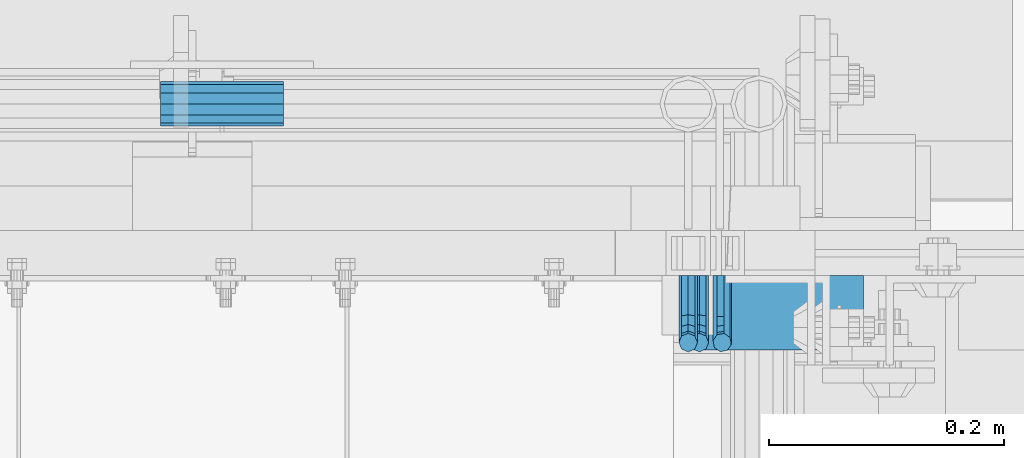
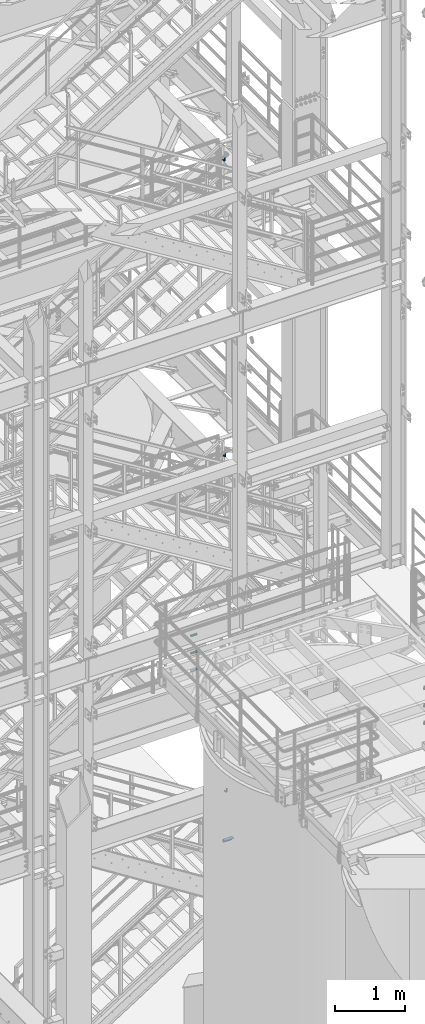
# One storey, part 1204 of 1876: 7 beams, 5 elements without a shape of their own.
"""IFC2X3 building model written with IfcOpenShell, lengths in millimetres."""

from ifc_helpers import new_model, si_unit, frame, origin_with_axes, place, context, subcontext, project, spatial, faceted_brep, material, type_object, element, aggregate, save


model = new_model("IFC2X3")

# Units and contexts
model_context = context("Model", 3, precision=1e-05, world=origin_with_axes())
body_context = subcontext(model_context, "Body", "Model", "MODEL_VIEW")
ifc_project = project(units=[si_unit("LENGTHUNIT", "METRE", prefix="MILLI"), si_unit("AREAUNIT", "SQUARE_METRE"), si_unit("VOLUMEUNIT", "CUBIC_METRE"), si_unit("MASSUNIT", "GRAM", prefix="KILO"), si_unit("TIMEUNIT", "SECOND"), si_unit("PLANEANGLEUNIT", "RADIAN"), si_unit("SOLIDANGLEUNIT", "STERADIAN"), si_unit("THERMODYNAMICTEMPERATUREUNIT", "DEGREE_CELSIUS"), si_unit("LUMINOUSINTENSITYUNIT", "LUMEN")], contexts=[model_context])

# Site, building, storey
site_placement = place(None, origin_with_axes())
site = spatial("IfcSite", under=ifc_project, at=site_placement, CompositionType="ELEMENT")
building_placement = place(site_placement, origin_with_axes())
building = spatial("IfcBuilding", under=site, at=building_placement, Name="Undefined", CompositionType="ELEMENT")
storey_placement = place(building_placement, origin_with_axes())
storey = spatial("IfcBuildingStorey", under=building, at=storey_placement, Name="Undefined", CompositionType="ELEMENT", Elevation=0.0)

# Assembly, beam
assembly_1_placement = place(storey_placement, origin_with_axes())
assembly_1 = element("IfcElementAssembly", 1, at=assembly_1_placement, inside=storey, Name="STRINGER", AssemblyPlace="NOTDEFINED", PredefinedType="RIGID_FRAME")
ifc_material = material(Name="STEEL/A36")
beam_type_1 = type_object("IfcBeamType", Name="L2-1/2X2-1/2X1/4", PredefinedType="NOTDEFINED")
beam_1_placement = place(assembly_1_placement, frame((6134.10000011796, -4832.34999887347, 2266.27941801296), z_axis=(0.0, -1.0, 0.0), x_axis=(1.0, 0.0, 0.0)))
beam_1 = element("IfcBeam", 2, at=beam_1_placement, type_object=beam_type_1, material=ifc_material, Name="ANGLE", ObjectType="L2-1/2X2-1/2X1/4", context=body_context, shape_type="Brep", body=[
    faceted_brep([(0.0, 31.75, -31.75), (0.0, 31.75, 31.75), (152.400073242188, 31.75, 31.75), (152.400073242188, 31.75, -31.75), (0.0, 25.3999999999996, 31.75), (152.400073242188, 25.3999999999996, 31.75), (0.0, 25.3999999999996, -25.3999999999996), (152.400073242188, 25.3999999999996, -25.3999999999996), (0.0, -31.75, -25.3999999999996), (152.400073242188, -31.75, -25.3999999999996), (0.0, -31.75, -31.75), (152.400073242188, -31.75, -31.75)], [[[0, 1, 2, 3]], [[1, 4, 5, 2]], [[4, 6, 7, 5]], [[6, 8, 9, 7]], [[8, 10, 11, 9]], [[10, 0, 3, 11]], [[5, 7, 9, 11, 3, 2]], [[10, 8, 6, 4, 1, 0]]]),
])
aggregate(assembly_1, [beam_1])

assembly_2_placement = place(storey_placement, origin_with_axes())
assembly_2 = element("IfcElementAssembly", 3, at=assembly_2_placement, inside=storey, Name="RAIL", AssemblyPlace="NOTDEFINED", PredefinedType="RIGID_FRAME")
beam_type_2 = type_object("IfcBeamType", PredefinedType="NOTDEFINED")
beam_2_placement = place(assembly_2_placement, frame((6146.79999403857, -4800.59999885446, 8978.89999872102), z_axis=(1.0, 0.0, 0.0), x_axis=(0.0, -1.0, 0.0)))
beam_2 = element("IfcBeam", 4, at=beam_2_placement, type_object=beam_type_2, material=ifc_material, Name="BRACKET", context=body_context, shape_type="Brep", body=[
    faceted_brep([(0.0, -7.9375, 0.0), (0.0, -5.61266007566822, -5.61266007566883), (23.8125, -5.61266007566883, -5.61266007566792), (23.8125, -7.9375, 0.0), (0.0, 0.0, -7.9375), (23.8125, 0.0, -7.9375), (0.0, 5.61266007566822, -5.61266007566883), (23.8125, 5.61266007566883, -5.61266007566792), (0.0, 7.9375, 0.0), (23.8125, 7.9375, 0.0), (0.0, 5.61266007566822, 5.61266007566883), (23.8125, 5.61266007566883, 5.61266007566792), (0.0, 0.0, 7.9375), (23.8125, 0.0, 7.9375), (0.0, -5.61266007566822, 5.61266007566883), (23.8125, -5.61266007566883, 5.61266007566792), (39.6077592547972, 4.79562758825296, 0.0), (38.7180815328547, 2.64775556579752, -5.61266007566792), (36.5702095103989, -2.53766620105534, -7.9375), (34.4223374879439, -7.72308796790867, -5.61266007566792), (33.5326597660014, -9.87095999036364, 0.0), (34.4223374879439, -7.72308796790867, 5.61266007566792), (36.5702095103989, -2.53766620105534, 7.9375), (38.7180815328547, 2.64775556579752, 5.61266007566792), (51.354423396765, -5.79557812911253, 5.61266007566792), (52.9983334724338, -4.15166805344461, 0.0), (47.385673396765, -9.76432812911298, 7.9375), (43.4169233967659, -13.733078129113, 5.61266007566792), (41.7730133210971, -15.3769882047809, 0.0), (43.4169233967659, -13.733078129113, -5.61266007566792), (47.385673396765, -9.76432812911298, -7.9375), (51.354423396765, -5.79557812911253, -5.61266007566792), (59.7977570916764, -18.4319199930233, 5.61266007566792), (61.9456291141314, -17.5422422710808, 0.0), (54.6123353248231, -20.5797920154787, 7.9375), (49.4269135579698, -22.7276640379341, 5.61266007566792), (47.2790415355148, -23.6173417598766, 0.0), (49.4269135579698, -22.7276640379341, -5.61266007566792), (54.6123353248231, -20.5797920154787, -7.9375), (59.7977570916764, -18.4319199930233, -5.61266007566792), (62.7626616015468, -33.3375015258789, 5.61266007566792), (65.0875015258789, -33.3375015258789, 0.0), (57.1500015258789, -33.3375015258789, 7.9375), (51.5373414502101, -33.3375015258789, 5.61266007566792), (49.2125015258789, -33.3375015258789, 0.0), (51.5373414502101, -33.3375015258789, -5.61266007566792), (57.1500015258789, -33.3375015258789, -7.9375), (62.7626616015468, -33.3375015258789, -5.61266007566792), (51.537341450211, -69.8499984741211, -5.61266007566792), (49.2125015258789, -69.8499984741211, 0.0), (57.1500015258789, -69.8499984741211, -7.9375), (62.7626616015468, -69.8499984741211, -5.61266007566792), (65.0875015258789, -69.8499984741211, 0.0), (62.7626616015468, -69.8499984741211, 5.61266007566792), (57.1500015258789, -69.8499984741211, 7.9375), (51.537341450211, -69.8499984741211, 5.61266007566792)], [[[0, 1, 2, 3]], [[1, 4, 5, 2]], [[4, 6, 7, 5]], [[6, 8, 9, 7]], [[8, 10, 11, 9]], [[10, 12, 13, 11]], [[12, 14, 15, 13]], [[14, 0, 3, 15]], [[14, 12, 10, 8, 6, 4, 1, 0]], [[7, 9, 16, 17]], [[5, 7, 17, 18]], [[2, 5, 18, 19]], [[3, 2, 19, 20]], [[15, 3, 20, 21]], [[13, 15, 21, 22]], [[11, 13, 22, 23]], [[9, 11, 23, 16]], [[23, 24, 25, 16]], [[22, 26, 24, 23]], [[21, 27, 26, 22]], [[20, 28, 27, 21]], [[19, 29, 28, 20]], [[18, 30, 29, 19]], [[17, 31, 30, 18]], [[16, 25, 31, 17]], [[24, 32, 33, 25]], [[26, 34, 32, 24]], [[27, 35, 34, 26]], [[28, 36, 35, 27]], [[29, 37, 36, 28]], [[30, 38, 37, 29]], [[31, 39, 38, 30]], [[25, 33, 39, 31]], [[32, 40, 41, 33]], [[34, 42, 40, 32]], [[35, 43, 42, 34]], [[36, 44, 43, 35]], [[37, 45, 44, 36]], [[38, 46, 45, 37]], [[39, 47, 46, 38]], [[33, 41, 47, 39]], [[44, 45, 48, 49]], [[45, 46, 50, 48]], [[46, 47, 51, 50]], [[47, 41, 52, 51]], [[41, 40, 53, 52]], [[40, 42, 54, 53]], [[42, 43, 55, 54]], [[43, 44, 49, 55]], [[50, 51, 52, 53, 54, 55, 49, 48]]]),
])
aggregate(assembly_2, [beam_2])

assembly_3_placement = place(storey_placement, origin_with_axes())
assembly_3 = element("IfcElementAssembly", 5, at=assembly_3_placement, inside=storey, Name="RAIL", AssemblyPlace="NOTDEFINED", PredefinedType="RIGID_FRAME")
beam_3_placement = place(assembly_3_placement, frame((6137.27499995292, -4800.59999885446, 14135.1), z_axis=(1.0, 0.0, 0.0), x_axis=(0.0, -1.0, 0.0)))
beam_3 = element("IfcBeam", 6, at=beam_3_placement, type_object=beam_type_2, material=ifc_material, Name="BRACKET", context=body_context, shape_type="Brep", body=[
    faceted_brep([(0.0, -7.9375, 0.0), (0.0, -5.61266007566822, -5.61266007566883), (23.8125, -5.61266007566883, -5.61266007566792), (23.8125, -7.9375, 0.0), (0.0, 0.0, -7.9375), (23.8125, 0.0, -7.9375), (0.0, 5.61266007566822, -5.61266007566883), (23.8125, 5.61266007566883, -5.61266007566792), (0.0, 7.9375, 0.0), (23.8125, 7.9375, 0.0), (0.0, 5.61266007566822, 5.61266007566883), (23.8125, 5.61266007566883, 5.61266007566792), (0.0, 0.0, 7.9375), (23.8125, 0.0, 7.9375), (0.0, -5.61266007566822, 5.61266007566883), (23.8125, -5.61266007566883, 5.61266007566792), (39.6077592547972, 4.79562758825296, 0.0), (38.7180815328547, 2.64775556579752, -5.61266007566792), (36.5702095103989, -2.53766620105534, -7.9375), (34.4223374879439, -7.72308796790867, -5.61266007566792), (33.5326597660014, -9.87095999036364, 0.0), (34.4223374879439, -7.72308796790867, 5.61266007566792), (36.5702095103989, -2.53766620105534, 7.9375), (38.7180815328547, 2.64775556579752, 5.61266007566792), (51.354423396765, -5.79557812911253, 5.61266007566792), (52.9983334724338, -4.15166805344461, 0.0), (47.385673396765, -9.76432812911298, 7.9375), (43.4169233967659, -13.733078129113, 5.61266007566792), (41.7730133210971, -15.3769882047809, 0.0), (43.4169233967659, -13.733078129113, -5.61266007566792), (47.385673396765, -9.76432812911298, -7.9375), (51.354423396765, -5.79557812911253, -5.61266007566792), (59.7977570916764, -18.4319199930233, 5.61266007566792), (61.9456291141314, -17.5422422710808, 0.0), (54.6123353248231, -20.5797920154787, 7.9375), (49.4269135579698, -22.7276640379341, 5.61266007566792), (47.2790415355148, -23.6173417598766, 0.0), (49.4269135579698, -22.7276640379341, -5.61266007566792), (54.6123353248231, -20.5797920154787, -7.9375), (59.7977570916764, -18.4319199930233, -5.61266007566792), (62.7626616015468, -33.3375015258789, 5.61266007566792), (65.0875015258789, -33.3375015258789, 0.0), (57.1500015258789, -33.3375015258789, 7.9375), (51.5373414502101, -33.3375015258789, 5.61266007566792), (49.2125015258789, -33.3375015258789, 0.0), (51.5373414502101, -33.3375015258789, -5.61266007566792), (57.1500015258789, -33.3375015258789, -7.9375), (62.7626616015468, -33.3375015258789, -5.61266007566792), (51.537341450211, -69.8499984741211, -5.61266007566792), (49.2125015258789, -69.8499984741211, 0.0), (57.1500015258789, -69.8499984741211, -7.9375), (62.7626616015468, -69.8499984741211, -5.61266007566792), (65.0875015258789, -69.8499984741211, 0.0), (62.7626616015468, -69.8499984741211, 5.61266007566792), (57.1500015258789, -69.8499984741211, 7.9375), (51.537341450211, -69.8499984741211, 5.61266007566792)], [[[0, 1, 2, 3]], [[1, 4, 5, 2]], [[4, 6, 7, 5]], [[6, 8, 9, 7]], [[8, 10, 11, 9]], [[10, 12, 13, 11]], [[12, 14, 15, 13]], [[14, 0, 3, 15]], [[14, 12, 10, 8, 6, 4, 1, 0]], [[7, 9, 16, 17]], [[5, 7, 17, 18]], [[2, 5, 18, 19]], [[3, 2, 19, 20]], [[15, 3, 20, 21]], [[13, 15, 21, 22]], [[11, 13, 22, 23]], [[9, 11, 23, 16]], [[23, 24, 25, 16]], [[22, 26, 24, 23]], [[21, 27, 26, 22]], [[20, 28, 27, 21]], [[19, 29, 28, 20]], [[18, 30, 29, 19]], [[17, 31, 30, 18]], [[16, 25, 31, 17]], [[24, 32, 33, 25]], [[26, 34, 32, 24]], [[27, 35, 34, 26]], [[28, 36, 35, 27]], [[29, 37, 36, 28]], [[30, 38, 37, 29]], [[31, 39, 38, 30]], [[25, 33, 39, 31]], [[32, 40, 41, 33]], [[34, 42, 40, 32]], [[35, 43, 42, 34]], [[36, 44, 43, 35]], [[37, 45, 44, 36]], [[38, 46, 45, 37]], [[39, 47, 46, 38]], [[33, 41, 47, 39]], [[44, 45, 48, 49]], [[45, 46, 50, 48]], [[46, 47, 51, 50]], [[47, 41, 52, 51]], [[41, 40, 53, 52]], [[40, 42, 54, 53]], [[42, 43, 55, 54]], [[43, 44, 49, 55]], [[50, 51, 52, 53, 54, 55, 49, 48]]]),
])
aggregate(assembly_3, [beam_3])

assembly_4_placement = place(storey_placement, origin_with_axes())
assembly_4 = element("IfcElementAssembly", 7, at=assembly_4_placement, inside=storey, Name="RAIL", AssemblyPlace="NOTDEFINED", PredefinedType="RIGID_FRAME")
beam_4_placement = place(assembly_4_placement, frame((6166.24687501242, -4800.59999885446, 3129.78376806244), z_axis=(0.844410015326383, 0.0, 0.535697420207059), x_axis=(0.0, -1.0, 0.0)))
beam_4 = element("IfcBeam", 8, at=beam_4_placement, type_object=beam_type_2, material=ifc_material, Name="BRACKET", context=body_context, shape_type="Brep", body=[
    faceted_brep([(0.0, -5.61266007566822, 5.61266007566883), (0.0, 0.0, 7.9375), (0.0, 5.61266007566822, 5.61266007566883), (0.0, 7.9375, 0.0), (0.0, 5.61266007566822, -5.61266007566883), (0.0, 0.0, -7.9375), (0.0, -5.61266007566822, -5.61266007566883), (0.0, -7.9375, 0.0), (25.7500019073486, 7.93750000000102, 9.09494701772928e-13), (25.7500019073486, 5.61266007566837, -5.61266007566837), (25.7500019073486, -6.82121026329696e-13, -7.93750000000091), (25.7500019073486, -5.6126600756694, -5.61266007566974), (25.7500019073486, -7.93750000000102, -1.81898940354586e-12), (25.7500019073486, -5.61266007566837, 5.61266007566746), (25.7500019073486, 6.82121026329696e-13, 7.93750000000045), (25.7500019073486, 5.6126600756694, 5.61266007566928), (38.4293366836664, 3.48299342205155, 6.96372994876174), (40.3311989638523, 5.48838972025123, 1.55372631168893), (40.7305556863994, 3.09647240503659, -4.01637957277262), (39.3934690994565, -2.29160580041184, -6.48369522136136), (37.103186391596, -7.51958175847221, -4.40290058978781), (35.20132411141, -9.5249780566719, 1.00710304728545), (34.8019673888657, -7.13306074145851, 6.57720893174746), (36.1390539758049, -1.74498253600871, 9.04452458033529), (44.9464670438292, -6.71427237123442, 12.1970638641865), (49.1783576787429, -2.58178409626339, 10.8112514273389), (42.4758531820917, -11.4627955199268, 9.32401168030583), (43.2137681863505, -14.0457330830792, 3.87508987960746), (46.7279514549882, -12.95003526696, -0.957797047369695), (50.9598420899019, -8.81754699198905, -2.34360948421772), (53.4304559516395, -4.06902384329646, 0.529442699663377), (52.6925409473806, -1.48608628014392, 5.97836450036175), (56.3606238862012, -11.6583650794599, 16.5694742441578), (60.952125596792, -11.9241272539106, 12.6003035112408), (50.8313923112155, -14.1513401749901, 16.9151723234295), (47.6033797389591, -17.942701540198, 13.4348925027043), (48.5675121547501, -20.8115211072019, 8.16733550011031), (53.159013865341, -21.0772832816523, 4.19816476719325), (58.6882454403267, -18.5843081861219, 3.85246668792206), (61.916258012584, -14.7929468209162, 7.33274650864814), (63.8525060225302, -24.2366360838653, 20.4114131579445), (64.8960754294303, -27.4426764670732, 15.3577905213597), (58.8827003833576, -22.3649223522546, 23.3617611737764), (52.8979032529824, -22.9239597913389, 22.4805607149005), (49.4039276223266, -25.5862718511769, 18.2840070589591), (50.4474970292276, -28.7923122343848, 13.2303844223738), (55.4173026683993, -30.6640259659952, 10.2800364065429), (61.4020997987745, -30.104988526911, 11.1612368654173), (64.8960754294312, -59.9102425789932, 35.955356977126), (61.4020997987755, -62.5725529476152, 31.7588022482705), (55.4173026684002, -63.1315900315748, 30.8776015641024), (50.4474970292276, -61.2598774889583, 33.8279503342364), (49.4039276223266, -58.0538391423651, 38.8815742628567), (52.8979032529824, -55.3915287737431, 43.0781289917122), (58.8827003833576, -54.8324916897835, 43.9593296758803), (63.8525060225302, -56.7042042324005, 41.0089809057463)], [[[0, 1, 2, 3, 4, 5, 6, 7]], [[4, 3, 8, 9]], [[5, 4, 9, 10]], [[6, 5, 10, 11]], [[7, 6, 11, 12]], [[0, 7, 12, 13]], [[1, 0, 13, 14]], [[2, 1, 14, 15]], [[3, 2, 15, 8]], [[8, 15, 16, 17]], [[9, 8, 17, 18]], [[10, 9, 18, 19]], [[11, 10, 19, 20]], [[12, 11, 20, 21]], [[13, 12, 21, 22]], [[14, 13, 22, 23]], [[15, 14, 23, 16]], [[23, 24, 25, 16]], [[22, 26, 24, 23]], [[21, 27, 26, 22]], [[20, 28, 27, 21]], [[19, 29, 28, 20]], [[18, 30, 29, 19]], [[17, 31, 30, 18]], [[16, 25, 31, 17]], [[25, 32, 33, 31]], [[24, 34, 32, 25]], [[26, 35, 34, 24]], [[27, 36, 35, 26]], [[28, 37, 36, 27]], [[29, 38, 37, 28]], [[30, 39, 38, 29]], [[31, 33, 39, 30]], [[33, 40, 41, 39]], [[32, 42, 40, 33]], [[34, 43, 42, 32]], [[35, 44, 43, 34]], [[36, 45, 44, 35]], [[37, 46, 45, 36]], [[38, 47, 46, 37]], [[39, 41, 47, 38]], [[47, 41, 48, 49]], [[46, 47, 49, 50]], [[45, 46, 50, 51]], [[44, 45, 51, 52]], [[43, 44, 52, 53]], [[42, 43, 53, 54]], [[40, 42, 54, 55]], [[41, 40, 55, 48]], [[54, 53, 52, 51, 50, 49, 48, 55]]]),
])
aggregate(assembly_4, [beam_4])

# Assembly, beams
assembly_5_placement = place(storey_placement, origin_with_axes())
assembly_5 = element("IfcElementAssembly", 9, at=assembly_5_placement, inside=storey, Name="RAIL", AssemblyPlace="NOTDEFINED", PredefinedType="RIGID_FRAME")
beam_type_3 = type_object("IfcBeamType", PredefinedType="NOTDEFINED")
beam_5_placement = place(assembly_5_placement, frame((5792.78700007784, -4654.55004997361, 5292.72500000001), z_axis=(0.0, 0.0, 1.0), x_axis=(-1.0, 0.0, 0.0)))
beam_5 = element("IfcBeam", 10, at=beam_5_placement, type_object=beam_type_3, material=ifc_material, Name="ROD", context=body_context, shape_type="Brep", body=[
    faceted_brep([(0.0, -18.8594999999996, 0.0), (0.0, -16.3328061026723, -9.42975000000024), (104.774, -16.3328061026723, -9.42975000000024), (104.774, -18.8594999999996, 0.0), (0.0, -9.42975000000024, -16.3328061026723), (104.774, -9.42975000000024, -16.3328061026723), (0.0, 0.0, -18.8594999999996), (104.774, 0.0, -18.8594999999996), (0.0, 9.42975000000024, -16.3328061026723), (104.774, 9.42975000000024, -16.3328061026723), (0.0, 16.3328061026723, -9.42975000000024), (104.774, 16.3328061026723, -9.42975000000024), (0.0, 18.8594999999996, 0.0), (104.774, 18.8594999999996, 0.0), (0.0, 16.3328061026723, 9.42975000000024), (104.774, 16.3328061026723, 9.42975000000024), (0.0, 9.42975000000024, 16.3328061026723), (104.774, 9.42975000000024, 16.3328061026723), (0.0, 0.0, 18.8594999999996), (104.774, 0.0, 18.8594999999996), (0.0, -9.42975000000024, 16.3328061026723), (104.774, -9.42975000000024, 16.3328061026723), (0.0, -16.3328061026723, 9.42975000000024), (104.774, -16.3328061026723, 9.42975000000024)], [[[0, 1, 2, 3]], [[1, 4, 5, 2]], [[4, 6, 7, 5]], [[6, 8, 9, 7]], [[8, 10, 11, 9]], [[10, 12, 13, 11]], [[12, 14, 15, 13]], [[14, 16, 17, 15]], [[16, 18, 19, 17]], [[18, 20, 21, 19]], [[20, 22, 23, 21]], [[22, 0, 3, 23]], [[5, 7, 9, 11, 13, 15, 17, 19, 21, 23, 3, 2]], [[22, 20, 18, 16, 14, 12, 10, 8, 6, 4, 1, 0]]]),
])
beam_6_placement = place(assembly_5_placement, frame((5792.78700007784, -4654.55004997361, 5597.52500000001), z_axis=(0.0, 0.0, 1.0), x_axis=(-1.0, 0.0, 0.0)))
beam_6 = element("IfcBeam", 11, at=beam_6_placement, type_object=beam_type_3, material=ifc_material, Name="ROD", context=body_context, shape_type="Brep", body=[
    faceted_brep([(0.0, -18.8594999999996, 0.0), (0.0, -16.3328061026723, -9.42975000000024), (104.774, -16.3328061026723, -9.42975000000024), (104.774, -18.8594999999996, 0.0), (0.0, -9.42975000000024, -16.3328061026723), (104.774, -9.42975000000024, -16.3328061026723), (0.0, 0.0, -18.8594999999996), (104.774, 0.0, -18.8594999999996), (0.0, 9.42975000000024, -16.3328061026723), (104.774, 9.42975000000024, -16.3328061026723), (0.0, 16.3328061026723, -9.42975000000024), (104.774, 16.3328061026723, -9.42975000000024), (0.0, 18.8594999999996, 0.0), (104.774, 18.8594999999996, 0.0), (0.0, 16.3328061026723, 9.42975000000024), (104.774, 16.3328061026723, 9.42975000000024), (0.0, 9.42975000000024, 16.3328061026723), (104.774, 9.42975000000024, 16.3328061026723), (0.0, 0.0, 18.8594999999996), (104.774, 0.0, 18.8594999999996), (0.0, -9.42975000000024, 16.3328061026723), (104.774, -9.42975000000024, 16.3328061026723), (0.0, -16.3328061026723, 9.42975000000024), (104.774, -16.3328061026723, 9.42975000000024)], [[[0, 1, 2, 3]], [[1, 4, 5, 2]], [[4, 6, 7, 5]], [[6, 8, 9, 7]], [[8, 10, 11, 9]], [[10, 12, 13, 11]], [[12, 14, 15, 13]], [[14, 16, 17, 15]], [[16, 18, 19, 17]], [[18, 20, 21, 19]], [[20, 22, 23, 21]], [[22, 0, 3, 23]], [[5, 7, 9, 11, 13, 15, 17, 19, 21, 23, 3, 2]], [[22, 20, 18, 16, 14, 12, 10, 8, 6, 4, 1, 0]]]),
])
beam_7_placement = place(assembly_5_placement, frame((5792.78700007784, -4654.55004997361, 5902.32500000001), z_axis=(0.0, 0.0, 1.0), x_axis=(-1.0, 0.0, 0.0)))
beam_7 = element("IfcBeam", 12, at=beam_7_placement, type_object=beam_type_3, material=ifc_material, Name="ROD", context=body_context, shape_type="Brep", body=[
    faceted_brep([(0.0, -18.8594999999996, 0.0), (0.0, -16.3328061026723, -9.42975000000024), (104.774, -16.3328061026723, -9.42975000000024), (104.774, -18.8594999999996, 0.0), (0.0, -9.42975000000024, -16.3328061026723), (104.774, -9.42975000000024, -16.3328061026723), (0.0, 0.0, -18.8594999999996), (104.774, 0.0, -18.8594999999996), (0.0, 9.42975000000024, -16.3328061026723), (104.774, 9.42975000000024, -16.3328061026723), (0.0, 16.3328061026723, -9.42975000000024), (104.774, 16.3328061026723, -9.42975000000024), (0.0, 18.8594999999996, 0.0), (104.774, 18.8594999999996, 0.0), (0.0, 16.3328061026723, 9.42975000000024), (104.774, 16.3328061026723, 9.42975000000024), (0.0, 9.42975000000024, 16.3328061026723), (104.774, 9.42975000000024, 16.3328061026723), (0.0, 0.0, 18.8594999999996), (104.774, 0.0, 18.8594999999996), (0.0, -9.42975000000024, 16.3328061026723), (104.774, -9.42975000000024, 16.3328061026723), (0.0, -16.3328061026723, 9.42975000000024), (104.774, -16.3328061026723, 9.42975000000024)], [[[0, 1, 2, 3]], [[1, 4, 5, 2]], [[4, 6, 7, 5]], [[6, 8, 9, 7]], [[8, 10, 11, 9]], [[10, 12, 13, 11]], [[12, 14, 15, 13]], [[14, 16, 17, 15]], [[16, 18, 19, 17]], [[18, 20, 21, 19]], [[20, 22, 23, 21]], [[22, 0, 3, 23]], [[5, 7, 9, 11, 13, 15, 17, 19, 21, 23, 3, 2]], [[22, 20, 18, 16, 14, 12, 10, 8, 6, 4, 1, 0]]]),
])
aggregate(assembly_5, [beam_5, beam_6, beam_7])

save(model, "model.ifc")
